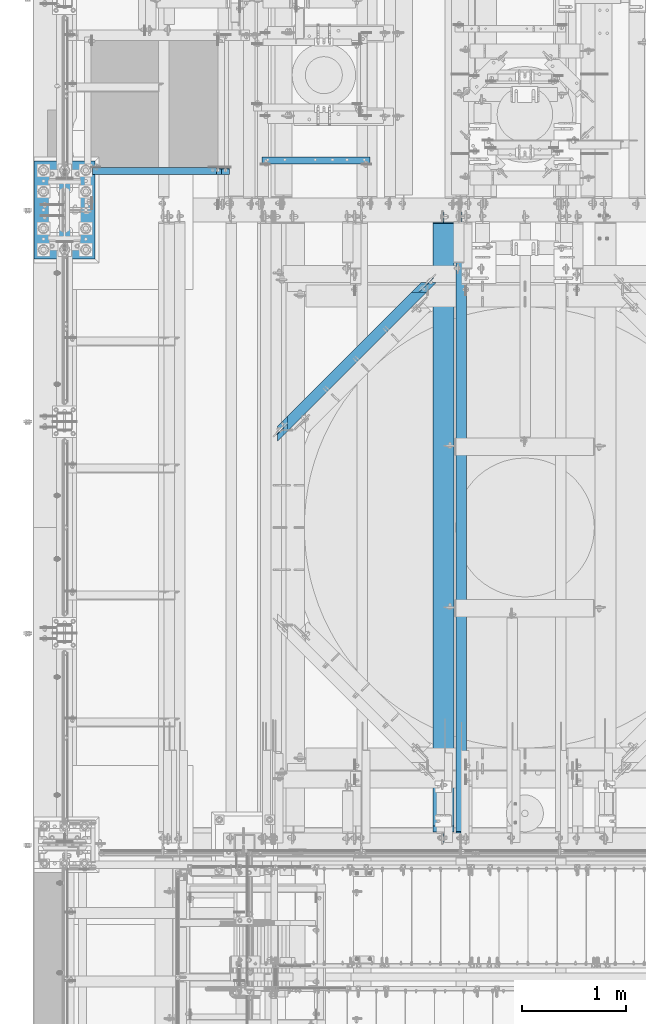
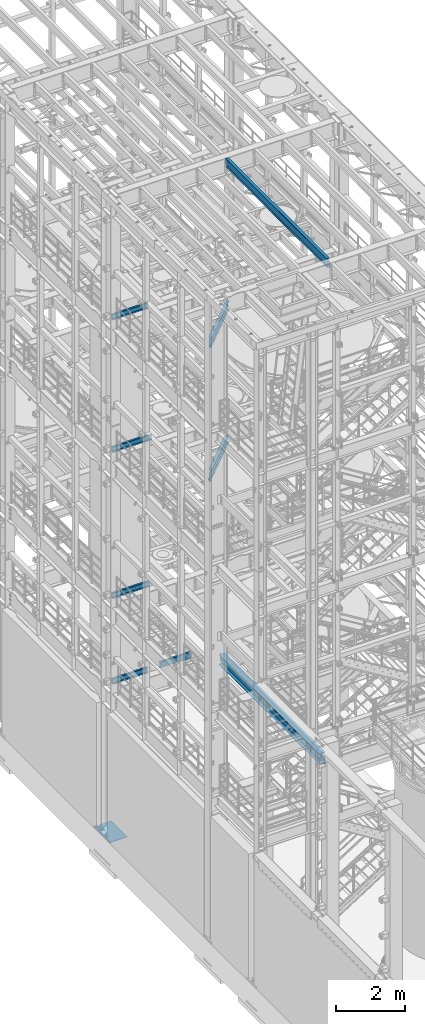
# One storey, part 1011 of 1876: 10 beams, 10 elements without a shape of their own.
"""IFC2X3 building model written with IfcOpenShell, lengths in millimetres."""

from ifc_helpers import new_model, si_unit, frame, origin_with_axes, place, context, subcontext, project, spatial, faceted_brep, material, type_object, element, aggregate, save


model = new_model("IFC2X3")

# Units and contexts
model_context = context("Model", 3, precision=1e-05, world=origin_with_axes())
body_context = subcontext(model_context, "Body", "Model", "MODEL_VIEW")
ifc_project = project(units=[si_unit("LENGTHUNIT", "METRE", prefix="MILLI"), si_unit("AREAUNIT", "SQUARE_METRE"), si_unit("VOLUMEUNIT", "CUBIC_METRE"), si_unit("MASSUNIT", "GRAM", prefix="KILO"), si_unit("TIMEUNIT", "SECOND"), si_unit("PLANEANGLEUNIT", "RADIAN"), si_unit("SOLIDANGLEUNIT", "STERADIAN"), si_unit("THERMODYNAMICTEMPERATUREUNIT", "DEGREE_CELSIUS"), si_unit("LUMINOUSINTENSITYUNIT", "LUMEN")], contexts=[model_context])

# Site, building, storey
site_placement = place(None, origin_with_axes())
site = spatial("IfcSite", under=ifc_project, at=site_placement, CompositionType="ELEMENT")
building_placement = place(site_placement, origin_with_axes())
building = spatial("IfcBuilding", under=site, at=building_placement, Name="Undefined", CompositionType="ELEMENT")
storey_placement = place(building_placement, origin_with_axes())
storey = spatial("IfcBuildingStorey", under=building, at=storey_placement, Name="Undefined", CompositionType="ELEMENT", Elevation=0.0)

# Assembly, beam
assembly_1_placement = place(storey_placement, origin_with_axes())
assembly_1 = element("IfcElementAssembly", 1, at=assembly_1_placement, inside=storey, Name="BEAM", AssemblyPlace="NOTDEFINED", PredefinedType="RIGID_FRAME")
ifc_material_1 = material(Name="STEEL/A992")
beam_type_1 = type_object("IfcBeamType", Name="W12X16", PredefinedType="NOTDEFINED")
beam_1_placement = place(assembly_1_placement, frame((1935.71088494531, -731.547206052242, 17830.8), z_axis=(0.0, 0.0, 1.0), x_axis=(0.707106781186548, 0.707106781186547, 0.0)))
beam_1 = element("IfcBeam", 2, at=beam_1_placement, type_object=beam_type_1, material=ifc_material_1, Name="BEAM", ObjectType="W12X16", context=body_context, shape_type="Brep", body=[
    faceted_brep([(2137.72686531034, 50.8000000000563, 146.049999999999), (2185.35186409801, 3.17500000005748, 146.049999999999), (229.150776004874, 3.17500000000564, 146.049999999999), (276.77577721721, 50.8000000000077, 146.049999999999), (175.175774630883, -50.7999999999961, -146.049999999999), (175.175774630883, -50.7999999999961, -152.400000000001), (2239.32686272415, -50.7999999999417, -152.400000000001), (2239.32686272415, -50.7999999999417, -146.049999999999), (276.7757772172, 50.8000000000075, -152.400000000001), (2137.72686531046, 50.8000000000563, -152.400000000001), (276.7757772172, 50.8000000000075, -146.049999999999), (2137.72686531046, 50.8000000000563, -146.049999999999), (229.150776004864, 3.17500000000564, -146.049999999999), (2185.35186409813, 3.17500000005748, -146.049999999999), (2202.78918539913, -3.17499999994243, -132.729229922596), (2196.43918556077, 3.17500000005771, -132.729229922596), (2203.31237584192, 3.17500000005748, -131.762500000008), (2209.66237568028, -3.17499999994243, -131.762500000008), (2196.96237603266, -3.17499999994288, -135.482243823073), (2190.6123761943, 3.17500000005725, -135.482243823073), (2193.06902648676, -3.17499999994288, -139.602420291227), (2186.7190266484, 3.17500000005771, -139.602420291227), (2191.70186393648, -3.17499999994311, -144.462499809273), (2185.35186409813, 3.17500000005748, -144.462499809273), (2191.70186393648, -3.17499999994311, -146.049999999999), (222.800775843219, -3.1749999999945, -146.049999999999), (222.800775843219, -3.1749999999945, -144.462499809273), (229.150776004863, 3.17500000000564, -144.462499809273), (221.433613258142, -3.17499999999472, -139.602420291227), (227.783613419787, 3.17500000000564, -139.602420291227), (217.54026361313, -3.17499999999472, -135.482243823073), (223.890263774775, 3.17500000000564, -135.482243823073), (211.713454098333, -3.17499999999472, -132.729229922596), (218.063454259978, 3.17500000000564, -132.729229922596), (204.840263642219, -3.17499999999518, -131.762500000008), (211.190263803864, 3.17500000000518, -131.762500000008), (142.297572892666, -3.17500000000632, -131.762500000008), (142.297572892665, 3.17499999999472, -131.762500000008), (142.297572892666, -3.17500000000632, 123.824999999997), (142.297572892665, 3.17499999999472, 123.824999999997), (204.84026364223, -3.17499999999495, 123.824999999997), (211.190263803875, 3.17500000000541, 123.824999999997), (211.713454098343, -3.17499999999472, 124.791729922585), (218.063454259988, 3.17500000000564, 124.791729922585), (217.54026361314, -3.1749999999945, 127.544743823062), (223.890263774785, 3.17500000000564, 127.544743823062), (221.433613258152, -3.17499999999472, 131.664920291216), (227.783613419797, 3.17500000000564, 131.664920291216), (222.800775843229, -3.17499999999427, 136.524999809262), (229.150776004874, 3.17500000000587, 136.524999809262), (2191.70186393636, -3.17499999994311, 146.049999999999), (2239.32686272402, -50.7999999999417, 146.049999999999), (175.175774630893, -50.7999999999961, 146.049999999999), (222.800775843229, -3.17499999999427, 146.049999999999), (2239.32686272402, -50.7999999999417, 152.400000000001), (2137.72686531034, 50.8000000000563, 152.400000000001), (276.77577721721, 50.8000000000077, 152.400000000001), (175.175774630893, -50.7999999999961, 152.400000000001), (2191.70186393636, -3.17499999994243, 136.524999809262), (2185.351864098, 3.17500000005703, 136.524999809262), (2193.06902648663, -3.17499999994311, 131.664920291216), (2186.71902664828, 3.17500000005748, 131.664920291216), (2196.96237603254, -3.17499999994243, 127.544743823062), (2190.61237619418, 3.17500000005748, 127.544743823062), (2202.78918539901, -3.1749999999422, 124.791729922585), (2196.43918556065, 3.17500000005748, 124.791729922585), (2209.66237568016, -3.1749999999422, 123.824999999997), (2203.3123758418, 3.17500000005771, 123.824999999997), (2272.20506418067, -3.17500000042401, 123.824999999997), (2272.20506418067, 3.17499999957363, 123.824999999997), (2272.20506418067, 3.17499999957363, -131.762500000008), (2272.20506418067, -3.17500000042401, -131.762500000008)], [[[0, 1, 2, 3]], [[4, 5, 6, 7]], [[5, 8, 9, 6]], [[8, 10, 11, 9]], [[10, 12, 13, 11]], [[14, 15, 16, 17]], [[18, 19, 15, 14]], [[20, 21, 19, 18]], [[22, 23, 21, 20]], [[7, 6, 9, 11, 13, 23, 22, 24]], [[25, 4, 7, 24]], [[10, 8, 5, 4, 25, 26, 27, 12]], [[27, 26, 28, 29]], [[29, 28, 30, 31]], [[31, 30, 32, 33]], [[33, 32, 34, 35]], [[35, 34, 36, 37]], [[37, 36, 38, 39]], [[40, 41, 39, 38]], [[41, 40, 42, 43]], [[43, 42, 44, 45]], [[45, 44, 46, 47]], [[47, 46, 48, 49]], [[50, 51, 52, 53]], [[54, 55, 56, 57]], [[51, 54, 57, 52]], [[56, 3, 2, 49, 48, 53, 52, 57]], [[55, 0, 3, 56]], [[54, 51, 50, 58, 59, 1, 0, 55]], [[60, 61, 59, 58]], [[62, 63, 61, 60]], [[64, 65, 63, 62]], [[66, 67, 65, 64]], [[67, 66, 68, 69]], [[16, 15, 19, 21, 23, 13, 12, 27, 29, 31, 33, 35, 37, 39, 41, 43, 45, 47, 49, 2, 1, 59, 61, 63, 65, 67, 69, 70]], [[17, 16, 70, 71]], [[66, 64, 62, 60, 58, 50, 53, 48, 46, 44, 42, 40, 38, 36, 34, 32, 30, 28, 26, 25, 24, 22, 20, 18, 14, 17, 71, 68]], [[70, 69, 68, 71]]]),
])
aggregate(assembly_1, [beam_1])

assembly_2_placement = place(storey_placement, origin_with_axes())
assembly_2 = element("IfcElementAssembly", 3, at=assembly_2_placement, inside=storey, Name="BEAM", AssemblyPlace="NOTDEFINED", PredefinedType="RIGID_FRAME")
beam_2_placement = place(assembly_2_placement, frame((3303.29389435104, 636.291142976258, 13157.2), z_axis=(0.0, 0.0, 1.0), x_axis=(-0.707106781186547, -0.707106781186548, 0.0)))
beam_2 = element("IfcBeam", 4, at=beam_2_placement, type_object=beam_type_1, material=ifc_material_1, Name="BEAM", ObjectType="W12X16", context=body_context, shape_type="Brep", body=[
    faceted_brep([(1696.01606852081, 50.7999999999645, 152.4), (1594.41609754501, -50.8000000000193, 152.4), (1594.41609754501, -50.8000000000193, 146.049999999999), (1642.04108393992, -3.17500000002701, 146.049999999999), (1642.04108393993, -3.17500000002656, 128.587499809264), (1648.39108212592, 3.17499999997199, 128.587499809264), (1648.39108212591, 3.17499999997199, 146.049999999999), (1696.01606852081, 50.7999999999645, 146.049999999999), (1643.40824631232, -3.17500000002701, 123.727420291218), (1649.75824449831, 3.17499999997221, 123.727420291218), (1647.30159535167, -3.17500000002678, 119.607243823064), (1653.65159353766, 3.17499999997199, 119.607243823064), (1653.12840396003, -3.17500000002724, 116.854229922586), (1659.47840214602, 3.17499999997176, 116.854229922586), (1660.00159334692, -3.17500000002724, 115.887499999999), (1666.35159153291, 3.17499999997176, 115.887499999999), (1786.46249810833, 3.17499999996949, 115.887499999999), (1780.11249992234, -3.17500000002929, 115.887499999999), (-321.749380982965, 50.8000000001275, -152.4), (-321.749380982965, 50.8000000001275, -146.049999999999), (1834.08748450325, 50.799999999962, -146.049999999999), (1834.08748450325, 50.799999999962, -152.4), (-220.14935195868, -50.7999999999001, -152.4), (1732.48751352743, -50.8000000000216, -152.4), (-220.14935195868, -50.7999999999001, -146.049999999999), (1732.48751352743, -50.8000000000216, -146.049999999999), (-267.774365563814, -3.1749999998874, -146.049999999999), (1780.11249992234, -3.17500000002929, -146.049999999999), (-82.0778965321463, -50.7999999999583, 152.4), (-183.677925556366, 50.8000000000693, 152.4), (-183.677925556366, 50.8000000000693, 146.049999999999), (-136.052911951263, 3.17500000005657, 146.049999999999), (-136.052911951128, 3.17500000005657, 128.587499809264), (-129.70291013711, -3.17499999994561, 128.587499809264), (-129.702910137249, -3.17499999994561, 146.049999999999), (-82.0778965321463, -50.7999999999583, 146.049999999999), (-137.420074714083, 3.17500000005657, 123.727420291218), (-131.070072900066, -3.17499999994379, 123.727420291218), (-141.313424865652, 3.17500000005839, 119.607243823064), (-134.963423051634, -3.17499999994379, 119.607243823064), (-147.140235138563, 3.17500000006112, 116.854229922586), (-140.790233324546, -3.17499999994016, 116.854229922586), (-154.013426488935, 3.17500000006385, 115.887499999999), (-147.663424674917, -3.17499999993743, 115.887499999999), (-274.124367377832, 3.17500000011478, 115.887499999999), (-267.774365563814, -3.1749999998874, 115.887499999999), (-274.124367377832, 3.17500000011478, -146.049999999999), (1786.46249810833, 3.17499999996949, -146.049999999999)], [[[0, 1, 2, 3, 4, 5, 6, 7]], [[5, 4, 8, 9]], [[9, 8, 10, 11]], [[11, 10, 12, 13]], [[13, 12, 14, 15]], [[16, 15, 14, 17]], [[18, 19, 20, 21]], [[22, 18, 21, 23]], [[24, 22, 23, 25]], [[26, 24, 25, 27]], [[28, 29, 30, 31, 32, 33, 34, 35]], [[33, 32, 36, 37]], [[37, 36, 38, 39]], [[39, 38, 40, 41]], [[41, 40, 42, 43]], [[43, 42, 44, 45]], [[46, 19, 18, 22, 24, 26, 45, 44]], [[19, 46, 47, 20]], [[27, 25, 23, 21, 20, 47, 16, 17]], [[12, 10, 8, 4, 3, 34, 33, 37, 39, 41, 43, 45, 26, 27, 17, 14]], [[35, 34, 3, 2]], [[28, 35, 2, 1]], [[29, 28, 1, 0]], [[30, 29, 0, 7]], [[31, 30, 7, 6]], [[47, 46, 44, 42, 40, 38, 36, 32, 31, 6, 5, 9, 11, 13, 15, 16]]]),
])
aggregate(assembly_2, [beam_2])

assembly_3_placement = place(storey_placement, origin_with_axes())
assembly_3 = element("IfcElementAssembly", 5, at=assembly_3_placement, inside=storey, Name="BEAM", AssemblyPlace="NOTDEFINED", PredefinedType="RIGID_FRAME")
beam_3_placement = place(assembly_3_placement, frame((3810.0, -4572.0, 22402.8), z_axis=(0.0, 0.0, 1.0), x_axis=(0.0, 1.0, 0.0)))
beam_3 = element("IfcBeam", 6, at=beam_3_placement, type_object=beam_type_1, material=ifc_material_1, Name="BEAM", ObjectType="W12X16", context=body_context, shape_type="Brep", body=[
    faceted_brep([(19.84375, -3.17499999999995, -126.999999999996), (19.84375, 3.17499999999995, -126.999999999996), (102.393750190735, 3.17500000000018, -127.000000000001), (102.393750190735, -3.17500000000018, -127.000000000001), (107.25382970878, 3.17500000000018, -127.966729922588), (107.25382970878, -3.17500000000018, -127.966729922588), (111.374006176934, 3.17500000000018, -130.719743823067), (111.374006176934, -3.17500000000018, -130.719743823067), (114.127020077412, 3.17500000000018, -134.839920291221), (114.127020077412, -3.17500000000018, -134.839920291221), (115.09375, -3.17500000000018, -139.699999809266), (115.09375, 3.17500000000018, -139.699999809266), (115.09375, 3.17500000000018, -146.05), (115.09375, 50.8000000000002, -146.05), (115.09375, 50.8000000000002, -152.4), (115.09375, -50.8000000000002, -152.4), (115.09375, -50.8000000000002, -146.05), (115.09375, -3.17500000000018, -146.05), (127.79375, 3.17500000000018, 146.05), (127.79375, 50.8000000000002, 146.05), (5968.20625, 50.8, 146.05), (5968.20625, 3.17499999999995, 146.05), (115.093750190735, -3.17500000000018, 114.299999999999), (115.093750190735, 3.17500000000018, 114.299999999999), (19.84375, 3.17500000000018, 114.299999999999), (19.84375, -3.17500000000018, 114.299999999999), (119.95382970878, -3.17500000000018, 115.266729922587), (119.95382970878, 3.17500000000018, 115.266729922587), (124.074006176934, -3.17500000000018, 118.019743823065), (124.074006176934, 3.17500000000018, 118.019743823065), (126.827020077412, -3.17500000000018, 122.139920291219), (126.827020077412, 3.17500000000018, 122.139920291219), (127.79375, -3.17500000000018, 126.999999809264), (127.79375, 3.17500000000018, 126.999999809264), (127.79375, 50.8000000000002, 152.4), (127.79375, -50.8000000000002, 152.4), (5968.20625, -50.8, 152.4), (5968.20625, 50.8, 152.4), (127.79375, -50.8000000000002, 146.05), (5968.20625, -50.8, 146.05), (127.79375, -3.17500000000018, 146.05), (5968.20625, -3.17499999999995, 146.05), (5968.20625, -3.17499999999995, 126.999999809264), (5968.20625, 3.17499999999995, 126.999999809264), (5969.17297992259, -3.17499999999995, 122.139920291219), (5969.17297992259, 3.17499999999995, 122.139920291219), (5971.92599382307, -3.17499999999995, 118.019743823065), (5971.92599382307, 3.17499999999995, 118.019743823065), (5976.04617029122, -3.17499999999995, 115.266729922587), (5976.04617029122, 3.17499999999995, 115.266729922587), (5980.90624980927, -3.17499999999995, 114.299999999999), (5980.90624980927, 3.17499999999995, 114.299999999999), (6076.15625, -3.17499999999995, 114.299999999999), (6076.15625, 3.17499999999995, 114.299999999999), (6076.15625, -3.17499999999995, -126.999999999996), (6076.15625, 3.17499999999995, -126.999999999996), (5993.60624980927, -3.17499999999995, -127.000000000001), (5993.60624980927, 3.17499999999995, -127.000000000001), (5988.74617029122, -3.17499999999995, -127.966729922588), (5988.74617029122, 3.17499999999995, -127.966729922588), (5984.62599382307, -3.17499999999995, -130.719743823067), (5984.62599382307, 3.17499999999995, -130.719743823067), (5981.87297992259, -3.17499999999995, -134.839920291221), (5981.87297992259, 3.17499999999995, -134.839920291221), (5980.90625, -3.17499999999995, -139.699999809266), (5980.90625, 3.17499999999995, -139.699999809266), (5980.90625, -3.17499999999995, -146.05), (5980.90625, -50.8, -146.05), (5980.90625, -50.8, -152.4), (5980.90625, 50.8, -152.4), (5980.90625, 50.8, -146.05), (5980.90625, 3.17499999999995, -146.05)], [[[0, 1, 2, 3]], [[3, 2, 4, 5]], [[5, 4, 6, 7]], [[7, 6, 8, 9]], [[10, 11, 12, 13, 14, 15, 16, 17]], [[9, 8, 11, 10]], [[18, 19, 20, 21]], [[22, 23, 24, 25]], [[26, 27, 23, 22]], [[28, 29, 27, 26]], [[30, 31, 29, 28]], [[32, 33, 31, 30]], [[34, 35, 36, 37]], [[35, 38, 39, 36]], [[38, 40, 41, 39]], [[35, 34, 19, 18, 33, 32, 40, 38]], [[19, 34, 37, 20]], [[36, 39, 41, 42, 43, 21, 20, 37]], [[44, 45, 43, 42]], [[46, 47, 45, 44]], [[48, 49, 47, 46]], [[50, 51, 49, 48]], [[52, 53, 51, 50]], [[53, 52, 54, 55]], [[54, 56, 57, 55]], [[58, 59, 57, 56]], [[60, 61, 59, 58]], [[62, 63, 61, 60]], [[64, 65, 63, 62]], [[66, 67, 68, 69, 70, 71, 65, 64]], [[17, 16, 67, 66]], [[16, 15, 68, 67]], [[15, 14, 69, 68]], [[14, 13, 70, 69]], [[13, 12, 71, 70]], [[59, 61, 63, 65, 71, 12, 11, 8, 6, 4, 2, 1, 24, 23, 27, 29, 31, 33, 18, 21, 43, 45, 47, 49, 51, 53, 55, 57]], [[25, 24, 1, 0]], [[52, 50, 48, 46, 44, 42, 41, 40, 32, 30, 28, 26, 22, 25, 0, 3, 5, 7, 9, 10, 17, 66, 64, 62, 60, 58, 56, 54]]]),
])
aggregate(assembly_3, [beam_3])

assembly_4_placement = place(storey_placement, origin_with_axes())
assembly_4 = element("IfcElementAssembly", 7, at=assembly_4_placement, inside=storey, Name="BEAM", AssemblyPlace="NOTDEFINED", PredefinedType="RIGID_FRAME")
ifc_material_2 = material(Name="STEEL/A36")
beam_type_2 = type_object("IfcBeamType", Name="C8X18.75", PredefinedType="NOTDEFINED")
beam_4_placement = place(assembly_4_placement, frame((1880.15454293187, 2000.24959106446, 4981.575), z_axis=(0.0, 0.0, -1.0), x_axis=(1.0, 0.0, 0.0)))
beam_4 = element("IfcBeam", 8, at=beam_4_placement, type_object=beam_type_2, material=ifc_material_2, Name="BEAM", ObjectType="C8X18.75", context=body_context, shape_type="Brep", body=[
    faceted_brep([(15.3204570681301, 31.75, -101.6), (15.3204570681301, 31.75, 101.6), (1050.37045706813, 31.75, 101.6), (1050.37045706813, 31.75, -101.6), (15.3204570681301, -31.75, 101.6), (1050.37045706813, -31.75, 101.6), (15.3204570681301, -31.75, 97.3645500000002), (1050.37045706813, -31.75, 97.3645500000002), (15.3204570681301, 19.05, 88.9012700000003), (1050.37045706813, 19.05, 88.9012700000003), (15.3204570681301, 19.05, -88.9012700000003), (1050.37045706813, 19.05, -88.9012700000003), (15.3204570681301, -31.75, -97.3645500000002), (1050.37045706813, -31.75, -97.3645500000002), (15.3204570681301, -31.75, -101.6), (1050.37045706813, -31.75, -101.6)], [[[0, 1, 2, 3]], [[1, 4, 5, 2]], [[4, 6, 7, 5]], [[6, 8, 9, 7]], [[8, 10, 11, 9]], [[10, 12, 13, 11]], [[12, 14, 15, 13]], [[14, 0, 3, 15]], [[5, 7, 9, 11, 13, 15, 3, 2]], [[14, 12, 10, 8, 6, 4, 1, 0]]]),
])
aggregate(assembly_4, [beam_4])

assembly_5_placement = place(storey_placement, origin_with_axes())
assembly_5 = element("IfcElementAssembly", 9, at=assembly_5_placement, inside=storey, Name="BEAM", AssemblyPlace="NOTDEFINED", PredefinedType="RIGID_FRAME")
beam_5_placement = place(assembly_5_placement, frame((0.0, 1898.65, 17881.6), z_axis=(0.0, 0.0, 1.0), x_axis=(1.0, 0.0, 0.0)))
beam_5 = element("IfcBeam", 10, at=beam_5_placement, type_object=beam_type_2, material=ifc_material_2, Name="BEAM", ObjectType="C8X18.75", context=body_context, shape_type="Brep", body=[
    faceted_brep([(266.7, 31.75, -101.599999999999), (266.7, 31.75, 101.599999999999), (1460.5, 31.75, 101.599999999999), (1460.5, 31.75, -101.599999999999), (266.7, -31.75, 101.599999999999), (1460.5, -31.75, 101.599999999999), (266.7, -31.75, 97.3645499999984), (1460.5, -31.75, 97.3645499999984), (266.7, 19.05, 88.9012699999985), (1460.5, 19.05, 88.9012699999985), (266.7, 19.05, -88.9012699999985), (1460.5, 19.05, -88.9012699999985), (266.7, -31.75, -97.3645499999984), (1460.5, -31.75, -97.3645499999984), (266.7, -31.75, -101.599999999999), (1460.5, -31.75, -101.599999999999)], [[[0, 1, 2, 3]], [[1, 4, 5, 2]], [[4, 6, 7, 5]], [[6, 8, 9, 7]], [[8, 10, 11, 9]], [[10, 12, 13, 11]], [[12, 14, 15, 13]], [[14, 0, 3, 15]], [[5, 7, 9, 11, 13, 15, 3, 2]], [[14, 12, 10, 8, 6, 4, 1, 0]]]),
])
aggregate(assembly_5, [beam_5])

assembly_6_placement = place(storey_placement, origin_with_axes())
assembly_6 = element("IfcElementAssembly", 11, at=assembly_6_placement, inside=storey, Name="BEAM", AssemblyPlace="NOTDEFINED", PredefinedType="RIGID_FRAME")
beam_6_placement = place(assembly_6_placement, frame((304.800000000003, 1898.65, 13208.0), z_axis=(0.0, 0.0, 1.0), x_axis=(1.0, 0.0, 0.0)))
beam_6 = element("IfcBeam", 12, at=beam_6_placement, type_object=beam_type_2, material=ifc_material_2, Name="BEAM", ObjectType="C8X18.75", context=body_context, shape_type="Brep", body=[
    faceted_brep([(1156.49375, -31.75, 101.6), (1156.49375, -31.75, 97.3645500000002), (1156.49375, 19.05, 88.9012700000003), (1156.49375, 19.05, 82.5499998092637), (1156.49375, 31.75, 82.5499998092637), (1156.49375, 31.75, 101.6), (1157.46047992258, 19.05, 77.6899202912173), (1157.46047992258, 31.75, 77.6899202912173), (1160.21349382306, 19.05, 73.5697438230636), (1160.21349382306, 31.75, 73.5697438230636), (1164.33367029122, 19.05, 70.8167299225861), (1164.33367029122, 31.75, 70.8167299225861), (1169.19374980926, 19.05, 69.8499999999985), (1169.19374980926, 31.75, 69.8499999999985), (1277.14375, 19.05, 69.8499999999985), (1277.14375, 31.75, 69.8499999999985), (-38.1000000000031, -31.75, -101.6), (-38.1000000000031, -31.75, -97.3645500000002), (-38.1000000000031, 19.05, -88.9012700000003), (-38.1000000000031, 19.05, 88.9012700000003), (-38.1000000000031, -31.75, 97.3645500000002), (-38.1000000000031, -31.75, 101.6), (-38.1000000000031, 31.75, 101.6), (-38.1000000000031, 31.75, -101.6), (1277.14375, 31.75, -101.6), (1277.14375, -31.75, -101.6), (1277.14375, -31.75, -97.3645500000002), (1277.14375, 19.05, -88.9012700000003)], [[[0, 1, 2, 3, 4, 5]], [[6, 7, 4, 3]], [[8, 9, 7, 6]], [[10, 11, 9, 8]], [[12, 13, 11, 10]], [[14, 15, 13, 12]], [[16, 17, 18, 19, 20, 21, 22, 23]], [[16, 23, 24, 25]], [[17, 16, 25, 26]], [[18, 17, 26, 27]], [[10, 8, 6, 3, 2, 19, 18, 27, 14, 12]], [[20, 19, 2, 1]], [[21, 20, 1, 0]], [[22, 21, 0, 5]], [[24, 23, 22, 5, 4, 7, 9, 11, 13, 15]], [[27, 26, 25, 24, 15, 14]]]),
])
aggregate(assembly_6, [beam_6])

assembly_7_placement = place(storey_placement, origin_with_axes())
assembly_7 = element("IfcElementAssembly", 13, at=assembly_7_placement, inside=storey, Name="BEAM", AssemblyPlace="NOTDEFINED", PredefinedType="RIGID_FRAME")
beam_7_placement = place(assembly_7_placement, frame((254.0, 1898.65, 8051.8), z_axis=(0.0, 0.0, 1.0), x_axis=(1.0, 0.0, 0.0)))
beam_7 = element("IfcBeam", 14, at=beam_7_placement, type_object=beam_type_2, material=ifc_material_2, Name="BEAM", ObjectType="C8X18.75", context=body_context, shape_type="Brep", body=[
    faceted_brep([(1203.32512207031, -31.75, 101.6), (1203.32512207031, -31.75, 97.3645500000002), (1203.32512207031, -19.0576219043483, 95.2499998092644), (1203.32512207031, 31.75, 95.2499998092644), (1203.32512207031, 31.75, 101.6), (1204.2918519929, 10.1145240623118, 90.3899202912189), (1204.2918519929, 31.75, 90.3899202912189), (1207.04486589337, 19.05, 86.2697438230653), (1207.04486589337, 31.75, 86.2697438230653), (1205.28653631682, 19.05, 88.9012700000003), (1211.16504236153, 19.05, 83.5167299225868), (1211.16504236153, 31.75, 83.5167299225868), (1216.02512187957, 19.05, 82.5499999999993), (1216.02512187957, 31.75, 82.5499999999993), (1254.12512207031, 19.05, 82.5499999999993), (1254.12512207031, 31.75, 82.5499999999993), (12.6999999999991, -31.75, -101.6), (12.6999999999991, -31.75, -97.3645500000002), (12.6999999999991, 19.0499999999993, -88.9012700000003), (12.6999999999991, 19.0499999999993, 88.9012700000003), (12.6999999999991, -31.75, 97.3645500000002), (12.6999999999991, -31.75, 101.6), (12.6999999999991, 31.75, 101.6), (12.6999999999991, 31.75, -101.6), (1254.12512207031, 31.75, -101.6), (1254.12512207031, -31.75, -101.6), (1254.12512207031, -31.75, -97.3645500000002), (1254.12512207031, 19.05, -88.9012700000003)], [[[0, 1, 2, 3, 4]], [[5, 6, 3, 2]], [[7, 8, 6, 5, 9]], [[10, 11, 8, 7]], [[12, 13, 11, 10]], [[14, 15, 13, 12]], [[16, 17, 18, 19, 20, 21, 22, 23]], [[16, 23, 24, 25]], [[17, 16, 25, 26]], [[18, 17, 26, 27]], [[10, 7, 9, 19, 18, 27, 14, 12]], [[2, 1, 20, 19, 9, 5]], [[21, 20, 1, 0]], [[22, 21, 0, 4]], [[24, 23, 22, 4, 3, 6, 8, 11, 13, 15]], [[27, 26, 25, 24, 15, 14]]]),
])
aggregate(assembly_7, [beam_7])

assembly_8_placement = place(storey_placement, origin_with_axes())
assembly_8 = element("IfcElementAssembly", 15, at=assembly_8_placement, inside=storey, Name="BEAM", AssemblyPlace="NOTDEFINED", PredefinedType="RIGID_FRAME")
beam_8_placement = place(assembly_8_placement, frame((355.6, 1898.65, 5029.2), z_axis=(0.0, 0.0, 1.0), x_axis=(1.0, 0.0, 0.0)))
beam_8 = element("IfcBeam", 16, at=beam_8_placement, type_object=beam_type_2, material=ifc_material_2, Name="BEAM", ObjectType="C8X18.75", context=body_context, shape_type="Brep", body=[
    faceted_brep([(-88.8999999999996, 31.75, -101.6), (-88.8999999999996, 31.75, 101.6), (1104.9, 31.75, 101.6), (1104.9, 31.75, -101.6), (-88.8999999999996, -31.75, 101.6), (1104.9, -31.75, 101.6), (-88.8999999999996, -31.75, 97.3645500000002), (1104.9, -31.75, 97.3645500000002), (-88.8999999999996, 19.05, 88.9012700000003), (1104.9, 19.05, 88.9012700000003), (-88.8999999999996, 19.05, -88.9012700000003), (1104.9, 19.05, -88.9012700000003), (-88.8999999999996, -31.75, -97.3645500000002), (1104.9, -31.75, -97.3645500000002), (-88.8999999999996, -31.75, -101.6), (1104.9, -31.75, -101.6)], [[[0, 1, 2, 3]], [[1, 4, 5, 2]], [[4, 6, 7, 5]], [[6, 8, 9, 7]], [[8, 10, 11, 9]], [[10, 12, 13, 11]], [[12, 14, 15, 13]], [[14, 0, 3, 15]], [[5, 7, 9, 11, 13, 15, 3, 2]], [[14, 12, 10, 8, 6, 4, 1, 0]]]),
])
aggregate(assembly_8, [beam_8])

assembly_9_placement = place(storey_placement, origin_with_axes())
assembly_9 = element("IfcElementAssembly", 17, at=assembly_9_placement, inside=storey, Name="BEAM", AssemblyPlace="NOTDEFINED", PredefinedType="RIGID_FRAME")
beam_type_3 = type_object("IfcBeamType", Name="W14X48", PredefinedType="NOTDEFINED")
beam_9_placement = place(assembly_9_placement, frame((3638.55, -4572.0, 4956.175), z_axis=(0.0, 0.0, 1.0), x_axis=(0.0, 1.0, 0.0)))
beam_9 = element("IfcBeam", 18, at=beam_9_placement, type_object=beam_type_3, material=ifc_material_1, Name="BEAM", ObjectType="W14X48", context=body_context, shape_type="Brep", body=[
    faceted_brep([(23.0187500000002, -3.96875, -142.874999999999), (23.0187500000002, 3.96875, -142.874999999999), (111.918750190734, 3.96875, -142.874999999999), (111.918750190734, -3.96875, -142.874999999999), (116.778829708779, 3.96875, -143.841729922587), (116.778829708779, -3.96875, -143.841729922587), (120.899006176933, 3.96875, -146.594743823065), (120.899006176933, -3.96875, -146.594743823065), (123.652020077411, 3.96875, -150.714920291219), (123.652020077411, -3.96875, -150.714920291219), (124.618749999999, -3.96875, -155.574999809264), (124.618749999999, 3.96875, -155.574999809264), (124.618749999999, 3.96875, -158.75), (124.618749999999, 101.6, -158.75), (124.618749999999, 101.6, -174.625), (124.618749999999, -101.6, -174.625), (124.618749999999, -101.6, -158.75), (124.618749999999, -3.96875, -158.75), (5968.20625, 101.6, 158.75), (5968.20625, 3.96875, 158.75), (181.768749999998, 3.96875, 158.75), (181.768749999998, 101.6, 158.75), (169.068750190733, -3.96875, 123.825000000001), (169.068750190733, 3.96875, 123.825000000001), (23.0187500000002, 3.96875, 123.825000000001), (23.0187500000002, -3.96875, 123.825000000001), (173.928829708779, -3.96875, 124.791729922588), (173.928829708779, 3.96875, 124.791729922588), (178.049006176932, -3.96875, 127.544743823067), (178.049006176932, 3.96875, 127.544743823067), (180.802020077411, -3.96875, 131.66492029122), (180.802020077411, 3.96875, 131.66492029122), (181.768749999998, -3.96875, 136.524999809266), (181.768749999998, 3.96875, 136.524999809266), (5968.20625, -101.6, 174.625), (5968.20625, 101.6, 174.625), (181.768749999998, 101.6, 174.625), (181.768749999998, -101.6, 174.625), (5968.20625, -101.6, 158.75), (181.768749999998, -101.6, 158.75), (5968.20625, -3.96875, 158.75), (181.768749999998, -3.96875, 158.75), (5968.20625, -3.96875, 149.224999809264), (5968.20625, 3.96875, 149.224999809264), (5969.17297992259, -3.96875, 144.364920291218), (5969.17297992259, 3.96875, 144.364920291218), (5971.92599382307, -3.96875, 140.244743823065), (5971.92599382307, 3.96875, 140.244743823065), (5976.04617029122, -3.96875, 137.491729922586), (5976.04617029122, 3.96875, 137.491729922586), (5980.90624980927, -3.96875, 136.524999999999), (5980.90624980927, 3.96875, 136.524999999999), (6076.15625, -3.96875, 136.525), (6076.15625, 3.96875, 136.525), (6076.15625, -3.96875, -142.875), (6076.15625, 3.96875, -142.875), (5987.25624980927, -3.96875, -142.875000000001), (5987.25624980927, 3.96875, -142.875000000001), (5982.39617029122, -3.96875, -143.841729922588), (5982.39617029122, 3.96875, -143.841729922588), (5978.27599382307, -3.96875, -146.594743823067), (5978.27599382307, 3.96875, -146.594743823067), (5975.52297992259, -3.96875, -150.714920291221), (5975.52297992259, 3.96875, -150.714920291221), (5974.55625, -3.96875, -155.574999809266), (5974.55625, 3.96875, -155.574999809266), (5974.55625, -3.96875, -158.75), (5974.55625, -101.6, -158.75), (5974.55625, -101.6, -174.625), (5974.55625, 101.6, -174.625), (5974.55625, 101.6, -158.75), (5974.55625, 3.96875, -158.75)], [[[0, 1, 2, 3]], [[3, 2, 4, 5]], [[5, 4, 6, 7]], [[7, 6, 8, 9]], [[10, 11, 12, 13, 14, 15, 16, 17]], [[9, 8, 11, 10]], [[18, 19, 20, 21]], [[22, 23, 24, 25]], [[26, 27, 23, 22]], [[28, 29, 27, 26]], [[30, 31, 29, 28]], [[32, 33, 31, 30]], [[34, 35, 36, 37]], [[38, 34, 37, 39]], [[40, 38, 39, 41]], [[37, 36, 21, 20, 33, 32, 41, 39]], [[35, 18, 21, 36]], [[34, 38, 40, 42, 43, 19, 18, 35]], [[44, 45, 43, 42]], [[46, 47, 45, 44]], [[48, 49, 47, 46]], [[50, 51, 49, 48]], [[52, 53, 51, 50]], [[53, 52, 54, 55]], [[54, 56, 57, 55]], [[58, 59, 57, 56]], [[60, 61, 59, 58]], [[62, 63, 61, 60]], [[64, 65, 63, 62]], [[66, 67, 68, 69, 70, 71, 65, 64]], [[67, 66, 17, 16]], [[68, 67, 16, 15]], [[69, 68, 15, 14]], [[70, 69, 14, 13]], [[71, 70, 13, 12]], [[6, 4, 2, 1, 24, 23, 27, 29, 31, 33, 20, 19, 43, 45, 47, 49, 51, 53, 55, 57, 59, 61, 63, 65, 71, 12, 11, 8]], [[25, 24, 1, 0]], [[66, 64, 62, 60, 58, 56, 54, 52, 50, 48, 46, 44, 42, 40, 41, 32, 30, 28, 26, 22, 25, 0, 3, 5, 7, 9, 10, 17]]]),
])
aggregate(assembly_9, [beam_9])

assembly_10_placement = place(storey_placement, origin_with_axes())
assembly_10 = element("IfcElementAssembly", 19, at=assembly_10_placement, inside=storey, Name="TEMPLATE", AssemblyPlace="NOTDEFINED", PredefinedType="RIGID_FRAME")
beam_type_4 = type_object("IfcBeamType", PredefinedType="NOTDEFINED")
beam_10_placement = place(assembly_10_placement, frame((0.0, 1054.1, 40.4815), z_axis=(-1.0, 0.0, 0.0), x_axis=(0.0, 1.0, 0.0)))
beam_10 = element("IfcBeam", 20, at=beam_10_placement, type_object=beam_type_4, material=ifc_material_2, Name="TEMPLATE", context=body_context, shape_type="Brep", body=[
    faceted_brep([(0.0, 2.3815, -292.1), (0.0, 2.3815, 292.1), (939.8, 2.3815, 292.1), (939.8, 2.3815, -292.1), (0.0, -2.3815, 292.1), (939.8, -2.3815, 292.1), (0.0, -2.3815, -292.1), (939.8, -2.3815, -292.1)], [[[0, 1, 2, 3]], [[1, 4, 5, 2]], [[4, 6, 7, 5]], [[6, 0, 3, 7]], [[5, 7, 3, 2]], [[6, 4, 1, 0]]]),
])
aggregate(assembly_10, [beam_10])

save(model, "model.ifc")
